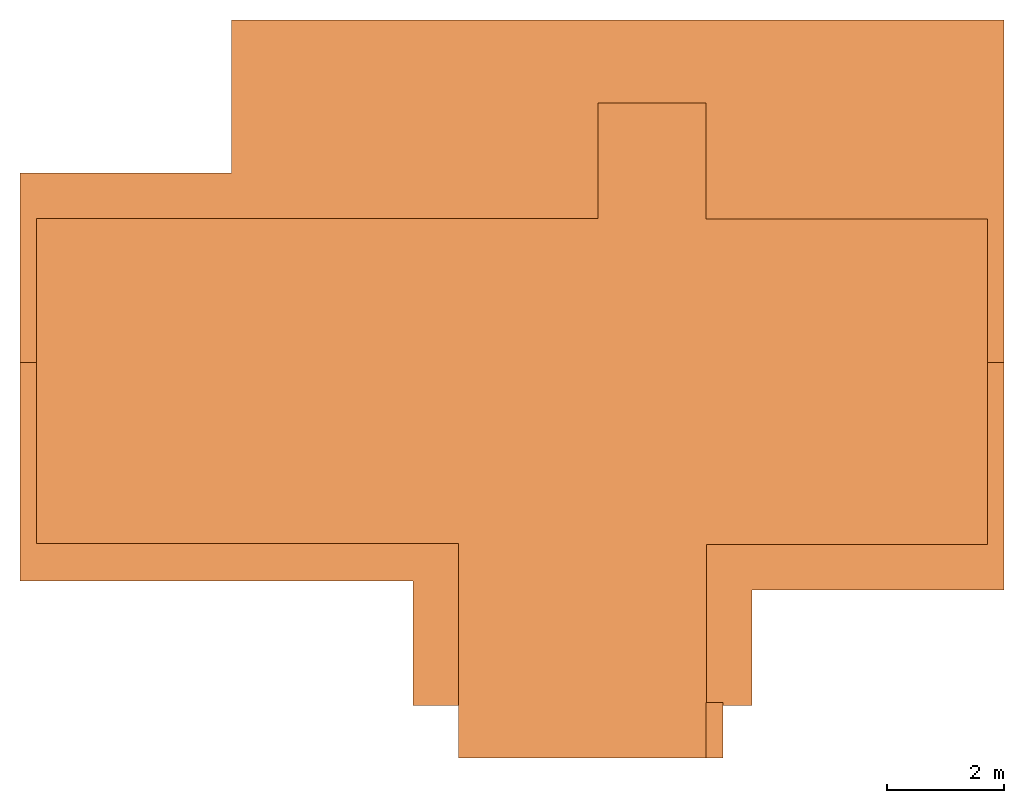
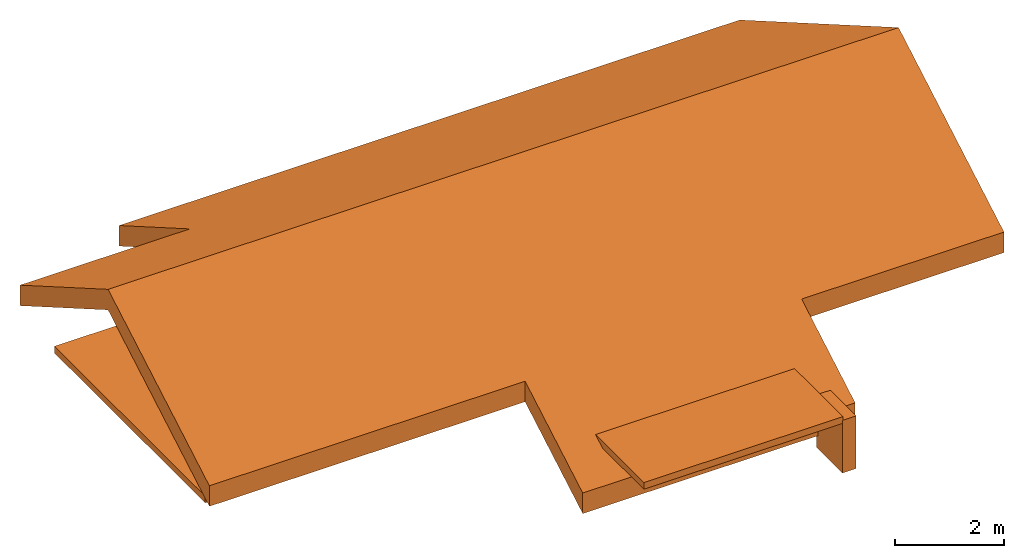
# One storey: 3 proxies.
"""IFC2X3 building model written with IfcOpenShell, lengths in millimetres."""

from ifc_helpers import new_model, entity, si_unit, converted_unit, direction, origin_with_axes, place, context, project, spatial, faceted_brep, element, save


model = new_model("IFC2X3")

# Units and contexts
model_context = context("Model", 3, precision=1e-05, world=origin_with_axes(), true_north=direction((0.0, 1.0)))
ifc_project = project(units=[si_unit("LENGTHUNIT", "METRE", prefix="MILLI"), converted_unit("PLANEANGLEUNIT", "Degrees", entity("IfcPlaneAngleMeasure", 0.017453293), si_unit("PLANEANGLEUNIT", "RADIAN"), dimensions=[0, 0, 0, 0, 0, 0, 0])], contexts=[model_context])

# Site, building, storey
storey_placement = place(None, origin_with_axes())
site_placement = place(storey_placement, origin_with_axes())
site = spatial("IfcSite", under=ifc_project, at=site_placement, CompositionType="ELEMENT")
building_placement = place(storey_placement, origin_with_axes())
building = spatial("IfcBuilding", under=site, at=building_placement, CompositionType="ELEMENT")
storey = spatial("IfcBuildingStorey", under=building, at=storey_placement, Name="ROOF", CompositionType="ELEMENT", Elevation=10.5)

# Proxies
placement = place(storey_placement, origin_with_axes())
element("IfcBuildingElementProxy", 1, at=placement, inside=storey, Name="267327", CompositionType="ELEMENT", context=model_context, body=[
    faceted_brep([(-9471.31063355574, 2347.7394900038, 11036.8963591806), (-5861.1345237002, 2347.72275315264, 11036.8654797347), (-9471.35144847748, -893.295902259728, 12908.1094598231), (-5861.32200922697, 4957.76199348318, 9530.00307487566), (7328.67298267476, 4957.7262515985, 9530.01195221876), (7328.82013348048, -893.348452583061, 12908.0873250468), (-2761.30792730823, -4622.18279321249, 10755.1335951314), (-9471.21298888769, -4622.24914377749, 10755.1421082015), (-9471.35144847748, -893.295902259728, 12908.1094598231), (7328.77934528374, -4774.30975927546, 10667.3914835488), (3028.67793930984, -4774.31956045926, 10667.3932189856), (-2761.16393690448, -6744.29148458511, 9529.97401495973), (7328.82013348048, -893.348452583061, 12908.0873250468), (3028.76383400799, -6744.18117165094, 9529.97337913966), (-5861.3045488186, 2347.75641245728, 11498.7361767433), (-9471.21440276094, 2347.73167438851, 11498.7611642948), (-9471.25336584159, -893.304497126641, 13369.9740875436), (7328.77018031189, 4957.71828216354, 9991.87685798534), (-5861.22391800314, 4957.75338442337, 9991.86819059556), (7328.65059070974, -893.314868414145, 13369.9580113816), (-9471.11490410482, -4622.25774219262, 11217.0068579219), (-2761.20969601413, -4622.19042001729, 11216.9981262499), (-9471.25336584159, -893.304497126641, 13369.9740875436), (-2761.33275301125, -6744.25921648529, 9991.90914058449), (3028.77569255025, -4774.32711922478, 11129.2580047775), (7328.65059070974, -893.314868414145, 13369.9580113816), (3028.83165927882, -6744.38930083721, 9991.89759289152), (7328.87661617648, -4774.31724290526, 11129.2562800145), (-9471.21440276094, 2347.73167438851, 11498.7611642948), (-5861.3045488186, 2347.75641245728, 11498.7361767433), (-5861.1345237002, 2347.72275315264, 11036.8654797347), (-9471.31063355574, 2347.7394900038, 11036.8963591806), (-5861.22391800314, 4957.75338442337, 9991.86819059556), (7328.77018031189, 4957.71828216354, 9991.87685798534), (7328.67298267476, 4957.7262515985, 9530.01195221876), (-5861.32200922697, 4957.76199348318, 9530.00307487566), (7328.87661617648, -4774.31724290526, 11129.2562800145), (3028.77569255025, -4774.32711922478, 11129.2580047775), (3028.67793930984, -4774.31956045926, 10667.3932189856), (7328.77934528374, -4774.30975927546, 10667.3914835488), (-2761.20969601413, -4622.19042001729, 11216.9981262499), (-9471.11490410482, -4622.25774219262, 11217.0068579219), (-9471.21298888769, -4622.24914377749, 10755.1421082015), (-2761.30792730823, -4622.18279321249, 10755.1335951314), (-9471.11490410482, -4622.25774219262, 11217.0068579219), (-9471.25336584159, -893.304497126641, 13369.9740875436), (-9471.21298888769, -4622.24914377749, 10755.1421082015), (-9471.21440276094, 2347.73167438851, 11498.7611642948), (-9471.35144847748, -893.295902259728, 12908.1094598231), (-9471.31063355574, 2347.7394900038, 11036.8963591806), (-5861.3045488186, 2347.75641245728, 11498.7361767433), (-5861.22391800314, 4957.75338442337, 9991.86819059556), (-5861.32200922697, 4957.76199348318, 9530.00307487566), (-5861.1345237002, 2347.72275315264, 11036.8654797347), (7328.77018031189, 4957.71828216354, 9991.87685798534), (7328.65059070974, -893.314868414145, 13369.9580113816), (7328.67298267476, 4957.7262515985, 9530.01195221876), (7328.87661617648, -4774.31724290526, 11129.2562800145), (7328.82013348048, -893.348452583061, 12908.0873250468), (7328.77934528374, -4774.30975927546, 10667.3914835488), (-2761.33275301125, -6744.25921648529, 9991.90914058449), (-2761.20969601413, -4622.19042001729, 11216.9981262499), (-2761.30792730823, -4622.18279321249, 10755.1335951314), (-2761.16393690448, -6744.29148458511, 9529.97401495973), (3028.83165927882, -6744.38930083721, 9991.89759289152), (-2761.33275301125, -6744.25921648529, 9991.90914058449), (-2761.16393690448, -6744.29148458511, 9529.97401495973), (3028.76383400799, -6744.18117165094, 9529.97337913966), (3028.77569255025, -4774.32711922478, 11129.2580047775), (3028.83165927882, -6744.38930083721, 9991.89759289152), (3028.76383400799, -6744.18117165094, 9529.97337913966), (3028.67793930984, -4774.31956045926, 10667.3932189856)], [[[0, 1, 2]], [[1, 3, 4]], [[1, 4, 2]], [[2, 4, 5]], [[6, 7, 8]], [[6, 8, 9]], [[6, 9, 10]], [[6, 10, 11]], [[8, 12, 9]], [[10, 13, 11]], [[14, 15, 16]], [[14, 16, 17]], [[14, 17, 18]], [[16, 19, 17]], [[20, 21, 22]], [[21, 23, 24]], [[21, 24, 22]], [[22, 24, 25]], [[23, 26, 24]], [[24, 27, 25]], [[28, 29, 30]], [[28, 30, 31]], [[32, 33, 34]], [[32, 34, 35]], [[36, 37, 38]], [[36, 38, 39]], [[40, 41, 42]], [[40, 42, 43]], [[44, 45, 46]], [[45, 47, 48]], [[45, 48, 46]], [[47, 49, 48]], [[50, 51, 52]], [[50, 52, 53]], [[54, 55, 56]], [[55, 57, 58]], [[55, 58, 56]], [[57, 59, 58]], [[60, 61, 62]], [[60, 62, 63]], [[64, 65, 66]], [[64, 66, 67]], [[68, 69, 70]], [[68, 70, 71]]]),
])
element("IfcBuildingElementProxy", 2, at=placement, inside=storey, Name="391561", CompositionType="ELEMENT", context=model_context, body=[
    faceted_brep([(2238.7829995602, -7644.2842385249, 9235.00007375119), (2238.7829995602, -6694.2842385249, 9235.00007375119), (2528.7829995602, -6694.2842385249, 9235.00007375119), (2528.7829995602, -7644.2842385249, 9235.00007375119), (2238.7829995602, -6694.2842385249, 10419.3889897668), (2238.7829995602, -7644.2842385249, 10419.3889897668), (2528.7829995602, -7644.2842385249, 10419.3889897668), (2528.7829995602, -6694.2842385249, 10419.3889897668), (2238.7829995602, -6694.2842385249, 9235.00007375119), (2238.7829995602, -6694.2842385249, 10419.3889897668), (2528.7829995602, -6694.2842385249, 10419.3889897668), (2528.7829995602, -6694.2842385249, 9235.00007375119), (2238.7829995602, -7644.2842385249, 10419.3889897668), (2238.7829995602, -7644.2842385249, 9235.00007375119), (2528.7829995602, -7644.2842385249, 9235.00007375119), (2528.7829995602, -7644.2842385249, 9949.55518849728), (2528.7829995602, -7644.2842385249, 10419.3889897668)], [[[0, 1, 2]], [[0, 2, 3]], [[4, 5, 6]], [[4, 6, 7]], [[8, 9, 10]], [[8, 10, 11]], [[12, 13, 14]], [[12, 14, 15]], [[12, 15, 16]]]),
    faceted_brep([(2238.7829995602, -6694.2842385249, 9235.00007375119), (2238.7829995602, -7644.2842385249, 9235.00007375119), (2238.7829995602, -7644.2842385249, 10419.3889897668), (2238.7829995602, -6694.2842385249, 10419.3889897668)], [[[0, 1, 2]], [[0, 2, 3]]]),
    faceted_brep([(2528.7829995602, -6694.2842385249, 9235.00007375119), (2528.7829995602, -6694.2842385249, 10419.3889897668), (2528.7829995602, -7644.2842385249, 9235.00007375119), (2528.7829995602, -7644.2842385249, 10419.3889897668), (2528.7829995602, -7644.2842385249, 9949.55518849728)], [[[0, 1, 2]], [[1, 3, 4]], [[1, 4, 2]]]),
])
element("IfcBuildingElementProxy", 3, at=placement, inside=storey, Name="392590", CompositionType="ELEMENT", context=model_context, body=[
    faceted_brep([(398.8949373189, 1567.6640872846, 10350.0), (398.8949373189, 3537.7158450971, 10350.0), (2238.8588045064, 1557.7676029096, 10350.0), (7048.7826326314, -3994.24460412165, 10350.0), (2248.7709138814, -3994.24460412165, 10350.0), (-1981.2867033061, -3984.34811974665, 10350.0), (-9191.2173673686, -3984.34811974665, 10350.0), (-9191.2173673686, 1567.6640872846, 10350.0), (2238.8588045064, 3537.7158450971, 10350.0), (7048.7826326314, 1557.7676029096, 10350.0), (2248.7709138814, -7644.2841549029, 10350.0), (-1981.2867033061, -7644.2841549029, 10350.0), (398.8949373189, 1567.6640872846, 10500.0), (-9191.2173673686, 1567.6640872846, 10500.0), (-1981.2867033061, -3984.34811974665, 10500.0), (2248.7709138814, -3994.24460412165, 10500.0), (7048.7826326314, -3994.24460412165, 10500.0), (2238.8588045064, 1557.7676029096, 10500.0), (2238.8588045064, 3537.7158450971, 10500.0), (398.8949373189, 3537.7158450971, 10500.0), (-9191.2173673686, -3984.34811974665, 10500.0), (-1981.2867033061, -7644.2841549029, 10500.0), (2248.7709138814, -7644.2841549029, 10500.0), (7048.7826326314, 1557.7676029096, 10500.0), (2238.8588045064, 3537.7158450971, 10350.0), (398.8949373189, 3537.7158450971, 10350.0), (398.8949373189, 3537.7158450971, 10500.0), (2238.8588045064, 3537.7158450971, 10500.0), (7048.7826326314, -3994.24460412165, 10350.0), (7048.7826326314, 1557.7676029096, 10350.0), (7048.7826326314, 1557.7676029096, 10500.0), (7048.7826326314, -3994.24460412165, 10500.0), (2248.7709138814, -3994.24460412165, 10350.0), (7048.7826326314, -3994.24460412165, 10350.0), (7048.7826326314, -3994.24460412165, 10500.0), (2248.7709138814, -3994.24460412165, 10500.0), (2248.7709138814, -7644.2841549029, 10350.0), (2248.7709138814, -3994.24460412165, 10350.0), (2248.7709138814, -3994.24460412165, 10500.0), (2248.7709138814, -7644.2841549029, 10500.0), (-1981.2867033061, -7644.2841549029, 10350.0), (2248.7709138814, -7644.2841549029, 10350.0), (2248.7709138814, -7644.2841549029, 10500.0), (-1981.2867033061, -7644.2841549029, 10500.0), (-1981.2867033061, -3984.34811974665, 10350.0), (-1981.2867033061, -7644.2841549029, 10350.0), (-1981.2867033061, -7644.2841549029, 10500.0), (-1981.2867033061, -3984.34811974665, 10500.0), (-9191.2173673686, -3984.34811974665, 10350.0), (-1981.2867033061, -3984.34811974665, 10350.0), (-1981.2867033061, -3984.34811974665, 10500.0), (-9191.2173673686, -3984.34811974665, 10500.0), (-9191.2173673686, 1567.6640872846, 10350.0), (-9191.2173673686, -3984.34811974665, 10350.0), (-9191.2173673686, -3984.34811974665, 10500.0), (-9191.2173673686, 1567.6640872846, 10500.0), (398.8949373189, 1567.6640872846, 10350.0), (-9191.2173673686, 1567.6640872846, 10350.0), (-9191.2173673686, 1567.6640872846, 10500.0), (398.8949373189, 1567.6640872846, 10500.0), (398.8949373189, 3537.7158450971, 10350.0), (398.8949373189, 1567.6640872846, 10350.0), (398.8949373189, 1567.6640872846, 10500.0), (398.8949373189, 3537.7158450971, 10500.0), (2238.8588045064, 1557.7676029096, 10350.0), (2238.8588045064, 3537.7158450971, 10350.0), (2238.8588045064, 3537.7158450971, 10500.0), (2238.8588045064, 1557.7676029096, 10500.0), (7048.7826326314, 1557.7676029096, 10350.0), (2238.8588045064, 1557.7676029096, 10350.0), (2238.8588045064, 1557.7676029096, 10500.0), (7048.7826326314, 1557.7676029096, 10500.0)], [[[0, 1, 2]], [[0, 2, 3]], [[0, 3, 4]], [[0, 4, 5]], [[0, 5, 6]], [[0, 6, 7]], [[1, 8, 2]], [[2, 9, 3]], [[4, 10, 5]], [[5, 10, 11]], [[12, 13, 14]], [[12, 14, 15]], [[12, 15, 16]], [[12, 16, 17]], [[12, 17, 18]], [[12, 18, 19]], [[13, 20, 14]], [[14, 21, 15]], [[15, 21, 22]], [[16, 23, 17]], [[24, 25, 26]], [[24, 26, 27]], [[28, 29, 30]], [[28, 30, 31]], [[32, 33, 34]], [[32, 34, 35]], [[36, 37, 38]], [[36, 38, 39]], [[40, 41, 42]], [[40, 42, 43]], [[44, 45, 46]], [[44, 46, 47]], [[48, 49, 50]], [[48, 50, 51]], [[52, 53, 54]], [[52, 54, 55]], [[56, 57, 58]], [[56, 58, 59]], [[60, 61, 62]], [[60, 62, 63]], [[64, 65, 66]], [[64, 66, 67]], [[68, 69, 70]], [[68, 70, 71]]]),
])

save(model, "model.ifc")
